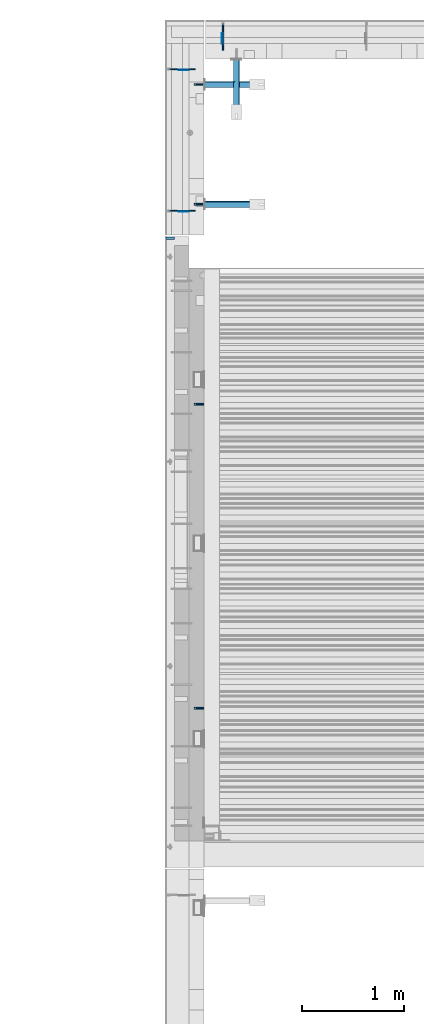
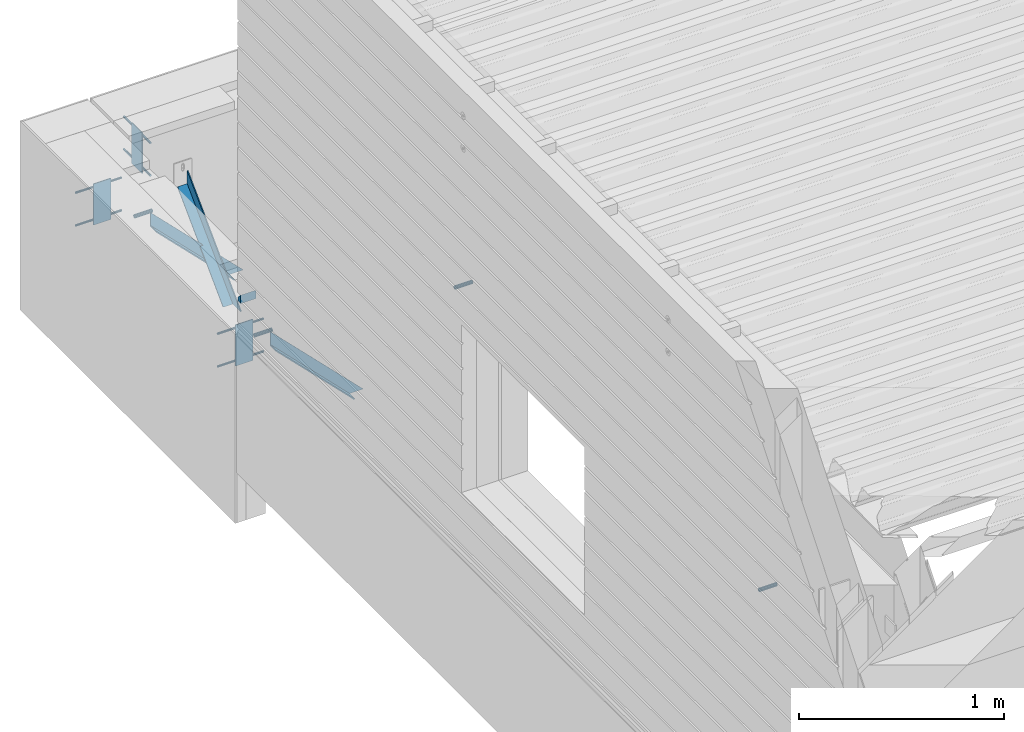
# One storey, part 51 of 153: 14 beams, 3 members, 19 elements without a shape of their own.
"""IFC2X3 building model written with IfcOpenShell, lengths in millimetres."""

from ifc_helpers import new_model, si_unit, frame, origin_with_axes, place, context, subcontext, project, spatial, faceted_brep, material, type_object, element, aggregate, save


model = new_model("IFC2X3")

# Units and contexts
model_context = context("Model", 3, precision=1e-05, world=origin_with_axes())
body_context = subcontext(model_context, "Body", "Model", "MODEL_VIEW")
ifc_project = project(units=[si_unit("LENGTHUNIT", "METRE", prefix="MILLI"), si_unit("AREAUNIT", "SQUARE_METRE"), si_unit("VOLUMEUNIT", "CUBIC_METRE"), si_unit("MASSUNIT", "GRAM", prefix="KILO"), si_unit("TIMEUNIT", "SECOND"), si_unit("PLANEANGLEUNIT", "RADIAN"), si_unit("SOLIDANGLEUNIT", "STERADIAN"), si_unit("THERMODYNAMICTEMPERATUREUNIT", "DEGREE_CELSIUS"), si_unit("LUMINOUSINTENSITYUNIT", "LUMEN")], contexts=[model_context])

# Site, building, storey
site_placement = place(None, origin_with_axes())
site = spatial("IfcSite", under=ifc_project, at=site_placement, CompositionType="ELEMENT")
building_placement = place(site_placement, origin_with_axes())
building = spatial("IfcBuilding", under=site, at=building_placement, CompositionType="ELEMENT")
storey_placement = place(building_placement, origin_with_axes())
storey = spatial("IfcBuildingStorey", under=building, at=storey_placement, Name="8", CompositionType="ELEMENT", Elevation=0.0)

# Assemblies, beams
assembly_1_placement = place(storey_placement, origin_with_axes())
assembly_1 = element("IfcElementAssembly", 1, at=assembly_1_placement, inside=storey, AssemblyPlace="NOTDEFINED", PredefinedType="REINFORCEMENT_UNIT")
assembly_2_placement = place(assembly_1_placement, origin_with_axes())
assembly_2 = element("IfcElementAssembly", 2, at=assembly_2_placement, Name="Steel Assembly", AssemblyPlace="NOTDEFINED", PredefinedType="RIGID_FRAME")
ifc_material_1 = material(Name="STEEL/Steel_Undefined")
beam_type_1 = type_object("IfcBeamType", PredefinedType="NOTDEFINED")
beam_1_placement = place(assembly_2_placement, frame((8000.0, 19245.0, 104755.0), z_axis=(0.0, 1.0, 0.0), x_axis=(-1.0, 3.00000001838171e-08, 0.0)))
beam_1 = element("IfcBeam", 3, at=beam_1_placement, type_object=beam_type_1, material=ifc_material_1, context=body_context, shape_type="Brep", body=[
    faceted_brep([(0.0, -8.49999999999272, -1.45519152283669e-11), (0.0, -7.36121593215648, 4.24999999998545), (100.000000000262, -7.36121593215648, 4.24999999998545), (100.000000000262, -8.49999999999272, -1.45519152283669e-11), (0.0, -4.24999999998545, 7.36121593216376), (100.000000000262, -4.24999999998545, 7.36121593216376), (0.0, 1.45519152283669e-11, 8.49999999998545), (100.000000000262, 1.45519152283669e-11, 8.49999999998545), (0.0, 4.25000000001455, 7.36121593216376), (100.000000000262, 4.25000000001455, 7.36121593216376), (0.0, 7.36121593217104, 4.24999999998545), (100.000000000262, 7.36121593217104, 4.24999999998545), (0.0, 8.50000000000728, 0.0), (100.000000000262, 8.50000000000728, 0.0), (0.0, 7.36121593217104, -4.25000000001455), (100.000000000262, 7.36121593217104, -4.25000000001455), (0.0, 4.25000000000728, -7.36121593219286), (100.000000000262, 4.25000000000728, -7.36121593219286), (0.0, 7.27595761418343e-12, -8.5), (100.000000000262, 7.27595761418343e-12, -8.5), (0.0, -4.24999999999272, -7.36121593217831), (100.000000000262, -4.24999999999272, -7.36121593217831), (0.0, -7.36121593215648, -4.25), (100.000000000262, -7.36121593215648, -4.25), (0.0, -10.4999999999927, -1.45519152283669e-11), (0.0, -9.09326673972828, -5.25000000001455), (100.000000000262, -9.09326673972828, -5.25000000001455), (100.000000000262, -10.4999999999927, -1.45519152283669e-11), (0.0, -5.24999999998545, -9.09326673974283), (100.000000000262, -5.24999999998545, -9.09326673974283), (0.0, 7.27595761418343e-12, -10.5), (100.000000000262, 7.27595761418343e-12, -10.5), (0.0, 5.25000000001455, -9.09326673975738), (100.000000000262, 5.25000000001455, -9.09326673975738), (0.0, 9.09326673975011, -5.25000000001455), (100.000000000262, 9.09326673975011, -5.25000000001455), (0.0, 10.5000000000073, -1.45519152283669e-11), (100.000000000262, 10.5000000000073, -1.45519152283669e-11), (0.0, 9.09326673975011, 5.25), (100.000000000262, 9.09326673975011, 5.25), (0.0, 5.25000000000728, 9.09326673972828), (100.000000000262, 5.25000000000728, 9.09326673972828), (0.0, 1.45519152283669e-11, 10.4999999999854), (100.000000000262, 1.45519152283669e-11, 10.4999999999854), (0.0, -5.24999999999272, 9.09326673972828), (100.000000000262, -5.24999999999272, 9.09326673972828), (0.0, -9.09326673972828, 5.24999999998545), (100.000000000262, -9.09326673972828, 5.24999999998545)], [[[0, 1, 2, 3]], [[1, 4, 5, 2]], [[4, 6, 7, 5]], [[6, 8, 9, 7]], [[8, 10, 11, 9]], [[10, 12, 13, 11]], [[12, 14, 15, 13]], [[14, 16, 17, 15]], [[16, 18, 19, 17]], [[18, 20, 21, 19]], [[20, 22, 23, 21]], [[22, 0, 3, 23]], [[24, 25, 26, 27]], [[25, 28, 29, 26]], [[28, 30, 31, 29]], [[30, 32, 33, 31]], [[32, 34, 35, 33]], [[34, 36, 37, 35]], [[36, 38, 39, 37]], [[38, 40, 41, 39]], [[40, 42, 43, 41]], [[42, 44, 45, 43]], [[44, 46, 47, 45]], [[46, 24, 27, 47]], [[29, 31, 33, 35, 37, 39, 41, 43, 45, 47, 27, 26], [5, 7, 9, 11, 13, 15, 17, 19, 21, 23, 3, 2]], [[46, 44, 42, 40, 38, 36, 34, 32, 30, 28, 25, 24], [22, 20, 18, 16, 14, 12, 10, 8, 6, 4, 1, 0]]]),
])
aggregate(assembly_2, [beam_1])
assembly_3_placement = place(assembly_1_placement, origin_with_axes())
assembly_3 = element("IfcElementAssembly", 4, at=assembly_3_placement, Name="Steel Assembly", AssemblyPlace="NOTDEFINED", PredefinedType="RIGID_FRAME")
beam_2_placement = place(assembly_3_placement, frame((8000.0, 16275.0, 104755.0), z_axis=(0.0, 1.0, 0.0), x_axis=(-1.0, 3.00000001838171e-08, 0.0)))
beam_2 = element("IfcBeam", 5, at=beam_2_placement, type_object=beam_type_1, material=ifc_material_1, context=body_context, shape_type="Brep", body=[
    faceted_brep([(0.0, -8.49999999999272, -1.45519152283669e-11), (0.0, -7.36121593215648, 4.24999999998545), (100.000000000262, -7.36121593215648, 4.24999999998545), (100.000000000262, -8.49999999999272, -1.45519152283669e-11), (0.0, -4.24999999998545, 7.36121593216376), (100.000000000262, -4.24999999998545, 7.36121593216376), (0.0, 1.45519152283669e-11, 8.49999999998545), (100.000000000262, 1.45519152283669e-11, 8.49999999998545), (0.0, 4.25000000001455, 7.36121593216376), (100.000000000262, 4.25000000001455, 7.36121593216376), (0.0, 7.36121593217104, 4.24999999998545), (100.000000000262, 7.36121593217104, 4.24999999998545), (0.0, 8.50000000000728, 0.0), (100.000000000262, 8.50000000000728, 0.0), (0.0, 7.36121593217104, -4.25000000001455), (100.000000000262, 7.36121593217104, -4.25000000001455), (0.0, 4.25000000000728, -7.36121593219286), (100.000000000262, 4.25000000000728, -7.36121593219286), (0.0, 7.27595761418343e-12, -8.5), (100.000000000262, 7.27595761418343e-12, -8.5), (0.0, -4.24999999999272, -7.36121593217831), (100.000000000262, -4.24999999999272, -7.36121593217831), (0.0, -7.36121593215648, -4.25), (100.000000000262, -7.36121593215648, -4.25), (0.0, -10.4999999999927, -1.45519152283669e-11), (0.0, -9.09326673972828, -5.25000000001455), (100.000000000262, -9.09326673972828, -5.25000000001455), (100.000000000262, -10.4999999999927, -1.45519152283669e-11), (0.0, -5.24999999998545, -9.09326673974283), (100.000000000262, -5.24999999998545, -9.09326673974283), (0.0, 7.27595761418343e-12, -10.5), (100.000000000262, 7.27595761418343e-12, -10.5), (0.0, 5.25000000001455, -9.09326673975738), (100.000000000262, 5.25000000001455, -9.09326673975738), (0.0, 9.09326673975011, -5.25000000001455), (100.000000000262, 9.09326673975011, -5.25000000001455), (0.0, 10.5000000000073, -1.45519152283669e-11), (100.000000000262, 10.5000000000073, -1.45519152283669e-11), (0.0, 9.09326673975011, 5.25), (100.000000000262, 9.09326673975011, 5.25), (0.0, 5.25000000000728, 9.09326673972828), (100.000000000262, 5.25000000000728, 9.09326673972828), (0.0, 1.45519152283669e-11, 10.4999999999854), (100.000000000262, 1.45519152283669e-11, 10.4999999999854), (0.0, -5.24999999999272, 9.09326673972828), (100.000000000262, -5.24999999999272, 9.09326673972828), (0.0, -9.09326673972828, 5.24999999998545), (100.000000000262, -9.09326673972828, 5.24999999998545)], [[[0, 1, 2, 3]], [[1, 4, 5, 2]], [[4, 6, 7, 5]], [[6, 8, 9, 7]], [[8, 10, 11, 9]], [[10, 12, 13, 11]], [[12, 14, 15, 13]], [[14, 16, 17, 15]], [[16, 18, 19, 17]], [[18, 20, 21, 19]], [[20, 22, 23, 21]], [[22, 0, 3, 23]], [[24, 25, 26, 27]], [[25, 28, 29, 26]], [[28, 30, 31, 29]], [[30, 32, 33, 31]], [[32, 34, 35, 33]], [[34, 36, 37, 35]], [[36, 38, 39, 37]], [[38, 40, 41, 39]], [[40, 42, 43, 41]], [[42, 44, 45, 43]], [[44, 46, 47, 45]], [[46, 24, 27, 47]], [[29, 31, 33, 35, 37, 39, 41, 43, 45, 47, 27, 26], [5, 7, 9, 11, 13, 15, 17, 19, 21, 23, 3, 2]], [[46, 44, 42, 40, 38, 36, 34, 32, 30, 28, 25, 24], [22, 20, 18, 16, 14, 12, 10, 8, 6, 4, 1, 0]]]),
])
aggregate(assembly_3, [beam_2])

assembly_4_placement = place(storey_placement, origin_with_axes())
assembly_4 = element("IfcElementAssembly", 6, at=assembly_4_placement, inside=storey, AssemblyPlace="NOTDEFINED", PredefinedType="REINFORCEMENT_UNIT")
assembly_5_placement = place(assembly_4_placement, origin_with_axes())
assembly_5 = element("IfcElementAssembly", 7, at=assembly_5_placement, Name="Steel Assembly", AssemblyPlace="NOTDEFINED", PredefinedType="RIGID_FRAME")
beam_3_placement = place(assembly_5_placement, frame((8000.00000000034, 22370.0020003493, 103285.0), z_axis=(0.0, -1.0, 0.0), x_axis=(-1.0, 3.00000001838171e-08, 0.0)))
beam_3 = element("IfcBeam", 8, at=beam_3_placement, type_object=beam_type_1, material=ifc_material_1, Name="1036-G", context=body_context, shape_type="Brep", body=[
    faceted_brep([(0.0, -8.49999999999272, -1.45519152283669e-11), (0.0, -7.36121593215648, 4.24999999998545), (100.000000000262, -7.36121593215648, 4.24999999998545), (100.000000000262, -8.49999999999272, -1.45519152283669e-11), (0.0, -4.24999999998545, 7.36121593216376), (100.000000000262, -4.24999999998545, 7.36121593216376), (0.0, 1.45519152283669e-11, 8.49999999998545), (100.000000000262, 1.45519152283669e-11, 8.49999999998545), (0.0, 4.25000000001455, 7.36121593216376), (100.000000000262, 4.25000000001455, 7.36121593216376), (0.0, 7.36121593217104, 4.24999999998545), (100.000000000262, 7.36121593217104, 4.24999999998545), (0.0, 8.50000000000728, 0.0), (100.000000000262, 8.50000000000728, 0.0), (0.0, 7.36121593217104, -4.25000000001455), (100.000000000262, 7.36121593217104, -4.25000000001455), (0.0, 4.25000000000728, -7.36121593219286), (100.000000000262, 4.25000000000728, -7.36121593219286), (0.0, 7.27595761418343e-12, -8.5), (100.000000000262, 7.27595761418343e-12, -8.5), (0.0, -4.24999999999272, -7.36121593217831), (100.000000000262, -4.24999999999272, -7.36121593217831), (0.0, -7.36121593215648, -4.25), (100.000000000262, -7.36121593215648, -4.25), (0.0, -10.4999999999927, -1.45519152283669e-11), (0.0, -9.09326673972828, -5.25000000001455), (100.000000000262, -9.09326673972828, -5.25000000001455), (100.000000000262, -10.4999999999927, -1.45519152283669e-11), (0.0, -5.24999999998545, -9.09326673974283), (100.000000000262, -5.24999999998545, -9.09326673974283), (0.0, 7.27595761418343e-12, -10.5), (100.000000000262, 7.27595761418343e-12, -10.5), (0.0, 5.25000000001455, -9.09326673975738), (100.000000000262, 5.25000000001455, -9.09326673975738), (0.0, 9.09326673975011, -5.25000000001455), (100.000000000262, 9.09326673975011, -5.25000000001455), (0.0, 10.5000000000073, -1.45519152283669e-11), (100.000000000262, 10.5000000000073, -1.45519152283669e-11), (0.0, 9.09326673975011, 5.25), (100.000000000262, 9.09326673975011, 5.25), (0.0, 5.25000000000728, 9.09326673972828), (100.000000000262, 5.25000000000728, 9.09326673972828), (0.0, 1.45519152283669e-11, 10.4999999999854), (100.000000000262, 1.45519152283669e-11, 10.4999999999854), (0.0, -5.24999999999272, 9.09326673972828), (100.000000000262, -5.24999999999272, 9.09326673972828), (0.0, -9.09326673972828, 5.24999999998545), (100.000000000262, -9.09326673972828, 5.24999999998545)], [[[0, 1, 2, 3]], [[1, 4, 5, 2]], [[4, 6, 7, 5]], [[6, 8, 9, 7]], [[8, 10, 11, 9]], [[10, 12, 13, 11]], [[12, 14, 15, 13]], [[14, 16, 17, 15]], [[16, 18, 19, 17]], [[18, 20, 21, 19]], [[20, 22, 23, 21]], [[22, 0, 3, 23]], [[24, 25, 26, 27]], [[25, 28, 29, 26]], [[28, 30, 31, 29]], [[30, 32, 33, 31]], [[32, 34, 35, 33]], [[34, 36, 37, 35]], [[36, 38, 39, 37]], [[38, 40, 41, 39]], [[40, 42, 43, 41]], [[42, 44, 45, 43]], [[44, 46, 47, 45]], [[46, 24, 27, 47]], [[29, 31, 33, 35, 37, 39, 41, 43, 45, 47, 27, 26], [5, 7, 9, 11, 13, 15, 17, 19, 21, 23, 3, 2]], [[46, 44, 42, 40, 38, 36, 34, 32, 30, 28, 25, 24], [22, 20, 18, 16, 14, 12, 10, 8, 6, 4, 1, 0]]]),
])
aggregate(assembly_5, [beam_3])
assembly_6_placement = place(assembly_4_placement, origin_with_axes())
assembly_6 = element("IfcElementAssembly", 9, at=assembly_6_placement, Name="Steel Assembly", AssemblyPlace="NOTDEFINED", PredefinedType="RIGID_FRAME")
beam_4_placement = place(assembly_6_placement, frame((8000.00000000034, 21199.9999481269, 103285.0), z_axis=(0.0, -1.0, 0.0), x_axis=(-1.0, 3.00000001838171e-08, 0.0)))
beam_4 = element("IfcBeam", 10, at=beam_4_placement, type_object=beam_type_1, material=ifc_material_1, Name="1036-G", context=body_context, shape_type="Brep", body=[
    faceted_brep([(0.0, -8.49999999999272, -1.45519152283669e-11), (0.0, -7.36121593215648, 4.24999999998545), (100.000000000262, -7.36121593215648, 4.24999999998545), (100.000000000262, -8.49999999999272, -1.45519152283669e-11), (0.0, -4.24999999998545, 7.36121593216376), (100.000000000262, -4.24999999998545, 7.36121593216376), (0.0, 1.45519152283669e-11, 8.49999999998545), (100.000000000262, 1.45519152283669e-11, 8.49999999998545), (0.0, 4.25000000001455, 7.36121593216376), (100.000000000262, 4.25000000001455, 7.36121593216376), (0.0, 7.36121593217104, 4.24999999998545), (100.000000000262, 7.36121593217104, 4.24999999998545), (0.0, 8.50000000000728, 0.0), (100.000000000262, 8.50000000000728, 0.0), (0.0, 7.36121593217104, -4.25000000001455), (100.000000000262, 7.36121593217104, -4.25000000001455), (0.0, 4.25000000000728, -7.36121593219286), (100.000000000262, 4.25000000000728, -7.36121593219286), (0.0, 7.27595761418343e-12, -8.5), (100.000000000262, 7.27595761418343e-12, -8.5), (0.0, -4.24999999999272, -7.36121593217831), (100.000000000262, -4.24999999999272, -7.36121593217831), (0.0, -7.36121593215648, -4.25), (100.000000000262, -7.36121593215648, -4.25), (0.0, -10.4999999999927, -1.45519152283669e-11), (0.0, -9.09326673972828, -5.25000000001455), (100.000000000262, -9.09326673972828, -5.25000000001455), (100.000000000262, -10.4999999999927, -1.45519152283669e-11), (0.0, -5.24999999998545, -9.09326673974283), (100.000000000262, -5.24999999998545, -9.09326673974283), (0.0, 7.27595761418343e-12, -10.5), (100.000000000262, 7.27595761418343e-12, -10.5), (0.0, 5.25000000001455, -9.09326673975738), (100.000000000262, 5.25000000001455, -9.09326673975738), (0.0, 9.09326673975011, -5.25000000001455), (100.000000000262, 9.09326673975011, -5.25000000001455), (0.0, 10.5000000000073, -1.45519152283669e-11), (100.000000000262, 10.5000000000073, -1.45519152283669e-11), (0.0, 9.09326673975011, 5.25), (100.000000000262, 9.09326673975011, 5.25), (0.0, 5.25000000000728, 9.09326673972828), (100.000000000262, 5.25000000000728, 9.09326673972828), (0.0, 1.45519152283669e-11, 10.4999999999854), (100.000000000262, 1.45519152283669e-11, 10.4999999999854), (0.0, -5.24999999999272, 9.09326673972828), (100.000000000262, -5.24999999999272, 9.09326673972828), (0.0, -9.09326673972828, 5.24999999998545), (100.000000000262, -9.09326673972828, 5.24999999998545)], [[[0, 1, 2, 3]], [[1, 4, 5, 2]], [[4, 6, 7, 5]], [[6, 8, 9, 7]], [[8, 10, 11, 9]], [[10, 12, 13, 11]], [[12, 14, 15, 13]], [[14, 16, 17, 15]], [[16, 18, 19, 17]], [[18, 20, 21, 19]], [[20, 22, 23, 21]], [[22, 0, 3, 23]], [[24, 25, 26, 27]], [[25, 28, 29, 26]], [[28, 30, 31, 29]], [[30, 32, 33, 31]], [[32, 34, 35, 33]], [[34, 36, 37, 35]], [[36, 38, 39, 37]], [[38, 40, 41, 39]], [[40, 42, 43, 41]], [[42, 44, 45, 43]], [[44, 46, 47, 45]], [[46, 24, 27, 47]], [[29, 31, 33, 35, 37, 39, 41, 43, 45, 47, 27, 26], [5, 7, 9, 11, 13, 15, 17, 19, 21, 23, 3, 2]], [[46, 44, 42, 40, 38, 36, 34, 32, 30, 28, 25, 24], [22, 20, 18, 16, 14, 12, 10, 8, 6, 4, 1, 0]]]),
])
aggregate(assembly_6, [beam_4])

# Beam
ifc_material_2 = material(Name="TIMBER/T24")
beam_type_2 = type_object("IfcBeamType", PredefinedType="NOTDEFINED")
beam_5_placement = place(assembly_1_placement, frame((7625.0, 20867.5, 103805.0), z_axis=(0.0, 1.0, 0.0), x_axis=(1.0, 0.0, 0.0)))
beam_5 = element("IfcBeam", 11, at=beam_5_placement, type_object=beam_type_2, material=ifc_material_2, context=body_context, shape_type="Brep", body=[
    faceted_brep([(85.0, -6.35918695479631e-09, 12.4999999935644), (1.45519152283669e-11, -3.63797880709171e-12, 12.4999999999964), (0.0, -25.0, -12.5), (85.0, -25.0, -12.5), (0.0, 25.0, -12.5), (0.0, 25.0, 12.5), (85.0, 25.0, 12.5), (85.0, 25.0, -12.5)], [[[0, 1, 2, 3]], [[4, 5, 6, 7]], [[7, 6, 0, 3]], [[4, 7, 3, 2]], [[5, 4, 2, 1]], [[6, 5, 1, 0]]]),
])

aggregate(assembly_1, [assembly_2, beam_5, assembly_3])

# Assemblies, beams
assembly_7_placement = place(storey_placement, origin_with_axes())
assembly_7 = element("IfcElementAssembly", 12, at=assembly_7_placement, inside=storey, AssemblyPlace="NOTDEFINED", PredefinedType="REINFORCEMENT_UNIT")
assembly_8_placement = place(assembly_7_placement, origin_with_axes())
assembly_8 = element("IfcElementAssembly", 13, at=assembly_8_placement, Name="Steel Assembly", AssemblyPlace="NOTDEFINED", PredefinedType="RIGID_FRAME")
beam_type_3 = type_object("IfcBeamType", Name="D12", PredefinedType="NOTDEFINED")
beam_6_placement = place(assembly_8_placement, frame((8184.99341918893, 22704.9948219476, 103224.99266456), z_axis=(-1.0, 3.00000001838171e-08, 0.0), x_axis=(-1.71000001528888e-07, 0.999999999916793, 1.28990000076059e-05)))
beam_6 = element("IfcBeam", 14, at=beam_6_placement, type_object=beam_type_3, material=ifc_material_1, Name="M12", ObjectType="D12", context=body_context, shape_type="Brep", body=[
    faceted_brep([(0.0, -6.0, -1.45519152283669e-11), (0.0, -4.24264068712, -4.24264068713819), (260.003353918641, -4.24264068710909, -4.24264068711909), (260.003353918641, -6.0, 0.0), (3.63797880709171e-12, 0.0, -6.0000000000291), (260.003353918644, 0.0, -6.0), (0.0, 4.24264068712, -4.24264068713819), (260.003353918641, 4.24264068710909, -4.24264068711909), (0.0, 6.0, -1.45519152283669e-11), (260.003353918644, 6.0, 9.09494701772928e-13), (0.0, 4.24264068712, 4.24264068709454), (260.003353918641, 4.24264068710909, 4.24264068711909), (0.0, 0.0, 5.99999999998545), (260.003353918644, 0.0, 6.0), (0.0, -4.24264068712, 4.24264068709454), (260.003353918641, -4.24264068710909, 4.24264068711909)], [[[0, 1, 2, 3]], [[1, 4, 5, 2]], [[4, 6, 7, 5]], [[6, 8, 9, 7]], [[8, 10, 11, 9]], [[10, 12, 13, 11]], [[12, 14, 15, 13]], [[14, 0, 3, 15]], [[5, 7, 9, 11, 13, 15, 3, 2]], [[14, 12, 10, 8, 6, 4, 1, 0]]]),
])
aggregate(assembly_8, [beam_6])
assembly_9_placement = place(assembly_7_placement, origin_with_axes())
assembly_9 = element("IfcElementAssembly", 15, at=assembly_9_placement, Name="Steel Assembly", AssemblyPlace="NOTDEFINED", PredefinedType="RIGID_FRAME")
beam_7_placement = place(assembly_9_placement, frame((8184.99341918893, 22704.9948219476, 103419.99266456), z_axis=(-1.0, 3.00000001838171e-08, 0.0), x_axis=(-1.71000001528888e-07, 0.999999999916793, 1.28990000076059e-05)))
beam_7 = element("IfcBeam", 16, at=beam_7_placement, type_object=beam_type_3, material=ifc_material_1, Name="M12", ObjectType="D12", context=body_context, shape_type="Brep", body=[
    faceted_brep([(0.0, -6.0, -1.45519152283669e-11), (0.0, -4.24264068712, -4.24264068713819), (260.003353918641, -4.24264068710909, -4.24264068711909), (260.003353918641, -6.0, 0.0), (3.63797880709171e-12, 0.0, -6.0000000000291), (260.003353918644, 0.0, -6.0), (0.0, 4.24264068712, -4.24264068713819), (260.003353918641, 4.24264068710909, -4.24264068711909), (0.0, 6.0, -1.45519152283669e-11), (260.003353918644, 6.0, 9.09494701772928e-13), (0.0, 4.24264068712, 4.24264068709454), (260.003353918641, 4.24264068710909, 4.24264068711909), (0.0, 0.0, 5.99999999998545), (260.003353918644, 0.0, 6.0), (0.0, -4.24264068712, 4.24264068709454), (260.003353918641, -4.24264068710909, 4.24264068711909)], [[[0, 1, 2, 3]], [[1, 4, 5, 2]], [[4, 6, 7, 5]], [[6, 8, 9, 7]], [[8, 10, 11, 9]], [[10, 12, 13, 11]], [[12, 14, 15, 13]], [[14, 0, 3, 15]], [[5, 7, 9, 11, 13, 15, 3, 2]], [[14, 12, 10, 8, 6, 4, 1, 0]]]),
])
aggregate(assembly_9, [beam_7])

# Assembly, beam
assembly_10_placement = place(assembly_4_placement, origin_with_axes())
assembly_10 = element("IfcElementAssembly", 17, at=assembly_10_placement, Name="Steel Assembly", AssemblyPlace="NOTDEFINED", PredefinedType="RIGID_FRAME")
beam_8_placement = place(assembly_10_placement, frame((7915.00517805244, 21135.0034191889, 103224.99266456), z_axis=(0.0, -1.0, 0.0), x_axis=(-0.999999999916793, -1.71000001528888e-07, 1.28990000076059e-05)))
beam_8 = element("IfcBeam", 18, at=beam_8_placement, type_object=beam_type_3, material=ifc_material_1, Name="M12", ObjectType="D12", context=body_context, shape_type="Brep", body=[
    faceted_brep([(0.0, -6.0, -1.45519152283669e-11), (0.0, -4.24264068712, -4.24264068713819), (260.003353918641, -4.24264068710909, -4.24264068711909), (260.003353918641, -6.0, 0.0), (3.63797880709171e-12, 0.0, -6.0000000000291), (260.003353918644, 0.0, -6.0), (0.0, 4.24264068712, -4.24264068713819), (260.003353918641, 4.24264068710909, -4.24264068711909), (0.0, 6.0, -1.45519152283669e-11), (260.003353918644, 6.0, 9.09494701772928e-13), (0.0, 4.24264068712, 4.24264068709454), (260.003353918641, 4.24264068710909, 4.24264068711909), (0.0, 0.0, 5.99999999998545), (260.003353918644, 0.0, 6.0), (0.0, -4.24264068712, 4.24264068709454), (260.003353918641, -4.24264068710909, 4.24264068711909)], [[[0, 1, 2, 3]], [[1, 4, 5, 2]], [[4, 6, 7, 5]], [[6, 8, 9, 7]], [[8, 10, 11, 9]], [[10, 12, 13, 11]], [[12, 14, 15, 13]], [[14, 0, 3, 15]], [[5, 7, 9, 11, 13, 15, 3, 2]], [[14, 12, 10, 8, 6, 4, 1, 0]]]),
])
aggregate(assembly_10, [beam_8])

assembly_11_placement = place(assembly_4_placement, origin_with_axes())
assembly_11 = element("IfcElementAssembly", 19, at=assembly_11_placement, Name="Steel Assembly", AssemblyPlace="NOTDEFINED", PredefinedType="RIGID_FRAME")
beam_9_placement = place(assembly_11_placement, frame((7915.00517805244, 21135.0034191889, 103419.99266456), z_axis=(0.0, -1.0, 0.0), x_axis=(-0.999999999916793, -1.71000001528888e-07, 1.28990000076059e-05)))
beam_9 = element("IfcBeam", 20, at=beam_9_placement, type_object=beam_type_3, material=ifc_material_1, Name="M12", ObjectType="D12", context=body_context, shape_type="Brep", body=[
    faceted_brep([(0.0, -6.0, -1.45519152283669e-11), (0.0, -4.24264068712, -4.24264068713819), (260.003353918641, -4.24264068710909, -4.24264068711909), (260.003353918641, -6.0, 0.0), (3.63797880709171e-12, 0.0, -6.0000000000291), (260.003353918644, 0.0, -6.0), (0.0, 4.24264068712, -4.24264068713819), (260.003353918641, 4.24264068710909, -4.24264068711909), (0.0, 6.0, -1.45519152283669e-11), (260.003353918644, 6.0, 9.09494701772928e-13), (0.0, 4.24264068712, 4.24264068709454), (260.003353918641, 4.24264068710909, 4.24264068711909), (0.0, 0.0, 5.99999999998545), (260.003353918644, 0.0, 6.0), (0.0, -4.24264068712, 4.24264068709454), (260.003353918641, -4.24264068710909, 4.24264068711909)], [[[0, 1, 2, 3]], [[1, 4, 5, 2]], [[4, 6, 7, 5]], [[6, 8, 9, 7]], [[8, 10, 11, 9]], [[10, 12, 13, 11]], [[12, 14, 15, 13]], [[14, 0, 3, 15]], [[5, 7, 9, 11, 13, 15, 3, 2]], [[14, 12, 10, 8, 6, 4, 1, 0]]]),
])
aggregate(assembly_11, [beam_9])

assembly_12_placement = place(assembly_4_placement, origin_with_axes())
assembly_12 = element("IfcElementAssembly", 21, at=assembly_12_placement, Name="Steel Assembly", AssemblyPlace="NOTDEFINED", PredefinedType="RIGID_FRAME")
beam_10_placement = place(assembly_12_placement, frame((7915.00517805244, 22520.0034191889, 103224.99266456), z_axis=(0.0, -1.0, 0.0), x_axis=(-0.999999999916793, -1.71000001528888e-07, 1.28990000076059e-05)))
beam_10 = element("IfcBeam", 22, at=beam_10_placement, type_object=beam_type_3, material=ifc_material_1, Name="M12", ObjectType="D12", context=body_context, shape_type="Brep", body=[
    faceted_brep([(0.0, -6.0, -1.45519152283669e-11), (0.0, -4.24264068712, -4.24264068713819), (260.003353918641, -4.24264068710909, -4.24264068711909), (260.003353918641, -6.0, 0.0), (3.63797880709171e-12, 0.0, -6.0000000000291), (260.003353918644, 0.0, -6.0), (0.0, 4.24264068712, -4.24264068713819), (260.003353918641, 4.24264068710909, -4.24264068711909), (0.0, 6.0, -1.45519152283669e-11), (260.003353918644, 6.0, 9.09494701772928e-13), (0.0, 4.24264068712, 4.24264068709454), (260.003353918641, 4.24264068710909, 4.24264068711909), (0.0, 0.0, 5.99999999998545), (260.003353918644, 0.0, 6.0), (0.0, -4.24264068712, 4.24264068709454), (260.003353918641, -4.24264068710909, 4.24264068711909)], [[[0, 1, 2, 3]], [[1, 4, 5, 2]], [[4, 6, 7, 5]], [[6, 8, 9, 7]], [[8, 10, 11, 9]], [[10, 12, 13, 11]], [[12, 14, 15, 13]], [[14, 0, 3, 15]], [[5, 7, 9, 11, 13, 15, 3, 2]], [[14, 12, 10, 8, 6, 4, 1, 0]]]),
])
aggregate(assembly_12, [beam_10])

assembly_13_placement = place(assembly_4_placement, origin_with_axes())
assembly_13 = element("IfcElementAssembly", 23, at=assembly_13_placement, Name="Steel Assembly", AssemblyPlace="NOTDEFINED", PredefinedType="RIGID_FRAME")
beam_11_placement = place(assembly_13_placement, frame((7915.00517805244, 22520.0034191889, 103419.99266456), z_axis=(0.0, -1.0, 0.0), x_axis=(-0.999999999916793, -1.71000001528888e-07, 1.28990000076059e-05)))
beam_11 = element("IfcBeam", 24, at=beam_11_placement, type_object=beam_type_3, material=ifc_material_1, Name="M12", ObjectType="D12", context=body_context, shape_type="Brep", body=[
    faceted_brep([(0.0, -6.0, -1.45519152283669e-11), (0.0, -4.24264068712, -4.24264068713819), (260.003353918641, -4.24264068710909, -4.24264068711909), (260.003353918641, -6.0, 0.0), (3.63797880709171e-12, 0.0, -6.0000000000291), (260.003353918644, 0.0, -6.0), (0.0, 4.24264068712, -4.24264068713819), (260.003353918641, 4.24264068710909, -4.24264068711909), (0.0, 6.0, -1.45519152283669e-11), (260.003353918644, 6.0, 9.09494701772928e-13), (0.0, 4.24264068712, 4.24264068709454), (260.003353918641, 4.24264068710909, 4.24264068711909), (0.0, 0.0, 5.99999999998545), (260.003353918644, 0.0, 6.0), (0.0, -4.24264068712, 4.24264068709454), (260.003353918641, -4.24264068710909, 4.24264068711909)], [[[0, 1, 2, 3]], [[1, 4, 5, 2]], [[4, 6, 7, 5]], [[6, 8, 9, 7]], [[8, 10, 11, 9]], [[10, 12, 13, 11]], [[12, 14, 15, 13]], [[14, 0, 3, 15]], [[5, 7, 9, 11, 13, 15, 3, 2]], [[14, 12, 10, 8, 6, 4, 1, 0]]]),
])
aggregate(assembly_13, [beam_11])

# Assembly
assembly_14_placement = place(assembly_7_placement, origin_with_axes())
assembly_14 = element("IfcElementAssembly", 25, at=assembly_14_placement, Name="Steel Assembly", AssemblyPlace="NOTDEFINED", PredefinedType="RIGID_FRAME")

aggregate(assembly_7, [assembly_8, assembly_14, assembly_9])

# Beam
ifc_material_3 = material(Name="STEEL/1.4301")
beam_type_4 = type_object("IfcBeamType", PredefinedType="NOTDEFINED")
beam_12_placement = place(assembly_14_placement, frame((8176.49477281603, 22819.9981743288, 103444.99266456), z_axis=(0.0, 1.0, 0.0), x_axis=(0.0, 0.0, -1.0)))
beam_12 = element("IfcBeam", 26, at=beam_12_placement, type_object=beam_type_4, material=ifc_material_3, Name="RST", context=body_context, shape_type="Brep", body=[
    faceted_brep([(0.0, 2.5, -49.9999999999964), (0.0, 2.49999999999909, 50.0000000000036), (245.0, 2.49999999999909, 50.0000000000036), (245.0, 2.5, -49.9999999999964), (0.0, -2.50000000000091, 50.0000000000036), (245.0, -2.50000000000091, 50.0000000000036), (0.0, -2.50000000000091, -49.9999999999964), (245.0, -2.50000000000091, -49.9999999999964)], [[[0, 1, 2, 3]], [[1, 4, 5, 2]], [[4, 6, 7, 5]], [[6, 0, 3, 7]], [[5, 7, 3, 2]], [[6, 4, 1, 0]]]),
])

aggregate(assembly_14, [beam_12])

# Assembly, beam
assembly_15_placement = place(assembly_4_placement, origin_with_axes())
assembly_15 = element("IfcElementAssembly", 27, at=assembly_15_placement, Name="Steel Assembly", AssemblyPlace="NOTDEFINED", PredefinedType="RIGID_FRAME")
beam_13_placement = place(assembly_15_placement, frame((7800.00182567124, 21126.504772816, 103444.99266456), z_axis=(-1.0, 3.00000001838171e-08, 0.0), x_axis=(0.0, 0.0, -1.0)))
beam_13 = element("IfcBeam", 28, at=beam_13_placement, type_object=beam_type_4, material=ifc_material_3, Name="RST", context=body_context, shape_type="Brep", body=[
    faceted_brep([(0.0, 2.5, -49.9999999999964), (0.0, 2.49999999999909, 50.0000000000036), (245.0, 2.49999999999909, 50.0000000000036), (245.0, 2.5, -49.9999999999964), (0.0, -2.50000000000091, 50.0000000000036), (245.0, -2.50000000000091, 50.0000000000036), (0.0, -2.50000000000091, -49.9999999999964), (245.0, -2.50000000000091, -49.9999999999964)], [[[0, 1, 2, 3]], [[1, 4, 5, 2]], [[4, 6, 7, 5]], [[6, 0, 3, 7]], [[5, 7, 3, 2]], [[6, 4, 1, 0]]]),
])
aggregate(assembly_15, [beam_13])

# Assembly
assembly_16_placement = place(assembly_4_placement, origin_with_axes())
assembly_16 = element("IfcElementAssembly", 29, at=assembly_16_placement, Name="Steel Assembly", AssemblyPlace="NOTDEFINED", PredefinedType="RIGID_FRAME")

aggregate(assembly_4, [assembly_5, assembly_6, assembly_10, assembly_15, assembly_11, assembly_12, assembly_16, assembly_13])

# Beam
beam_14_placement = place(assembly_16_placement, frame((7800.00182567124, 22511.504772816, 103444.99266456), z_axis=(-1.0, 3.00000001838171e-08, 0.0), x_axis=(0.0, 0.0, -1.0)))
beam_14 = element("IfcBeam", 30, at=beam_14_placement, type_object=beam_type_4, material=ifc_material_3, Name="RST", context=body_context, shape_type="Brep", body=[
    faceted_brep([(0.0, 2.5, -49.9999999999964), (0.0, 2.49999999999909, 50.0000000000036), (245.0, 2.49999999999909, 50.0000000000036), (245.0, 2.5, -49.9999999999964), (0.0, -2.50000000000091, 50.0000000000036), (245.0, -2.50000000000091, 50.0000000000036), (0.0, -2.50000000000091, -49.9999999999964), (245.0, -2.50000000000091, -49.9999999999964)], [[[0, 1, 2, 3]], [[1, 4, 5, 2]], [[4, 6, 7, 5]], [[6, 0, 3, 7]], [[5, 7, 3, 2]], [[6, 4, 1, 0]]]),
])

aggregate(assembly_16, [beam_14])

# Assembly, member
assembly_17_placement = place(storey_placement, origin_with_axes())
assembly_17 = element("IfcElementAssembly", 31, at=assembly_17_placement, inside=storey, Name="Steel Assembly", AssemblyPlace="NOTDEFINED", PredefinedType="RIGID_FRAME")
ifc_material_4 = material(Name="STEEL/S355J2")
member_type = type_object("IfcMemberType", PredefinedType="NOTDEFINED")
member_1_placement = place(assembly_17_placement, frame((7984.7567567571, 22370.0020003504, 103233.816878982), z_axis=(0.708108108195998, 0.0, 0.706104034195447), x_axis=(0.706104034195441, 0.0, -0.708108108196004)))
member_1 = element("IfcMember", 32, at=member_1_placement, type_object=member_type, material=ifc_material_4, Name="2", context=body_context, shape_type="Brep", body=[
    faceted_brep([(60.1702928045706, 30.0, -30.0), (-5.28234522789717e-09, 30.0, 30.0), (739.999999918371, 30.0, 30.0000000000146), (680.169810768777, 30.0, -30.0), (-5.28234522789717e-09, 24.0, 30.0), (739.999999918371, 24.0, 30.0000000000146), (54.1532635235926, 24.0, -24.0), (686.152829683742, 24.0, -23.9999999999854), (54.1532635235926, -30.0, -24.0), (686.152829683742, -30.0, -23.9999999999854), (60.1702928045706, -30.0, -30.0), (680.169810768777, -30.0, -30.0)], [[[0, 1, 2, 3]], [[1, 4, 5, 2]], [[4, 6, 7, 5]], [[6, 8, 9, 7]], [[8, 10, 11, 9]], [[10, 0, 3, 11]], [[5, 7, 9, 11, 3, 2]], [[10, 8, 6, 4, 1, 0]]]),
])
aggregate(assembly_17, [member_1])

assembly_18_placement = place(storey_placement, origin_with_axes())
assembly_18 = element("IfcElementAssembly", 33, at=assembly_18_placement, inside=storey, Name="Steel Assembly", AssemblyPlace="NOTDEFINED", PredefinedType="RIGID_FRAME")
member_2_placement = place(assembly_18_placement, frame((8315.0, 22635.2432432444, 103233.816878982), z_axis=(0.0, -0.708108108195998, 0.706104034195447), x_axis=(0.0, -0.706104034195442, -0.708108108196003)))
member_2 = element("IfcMember", 34, at=member_2_placement, type_object=member_type, material=ifc_material_4, Name="2", context=body_context, shape_type="Brep", body=[
    faceted_brep([(60.1702928045706, 30.0, -30.0), (-5.28234522789717e-09, 30.0, 30.0), (739.999999918371, 30.0, 30.0000000000146), (680.169810768777, 30.0, -30.0), (-5.28234522789717e-09, 24.0, 30.0), (739.999999918371, 24.0, 30.0000000000146), (54.1532635235926, 24.0, -24.0), (686.152829683742, 24.0, -23.9999999999854), (54.1532635235926, -30.0, -24.0), (686.152829683742, -30.0, -23.9999999999854), (60.1702928045706, -30.0, -30.0), (680.169810768777, -30.0, -30.0)], [[[0, 1, 2, 3]], [[1, 4, 5, 2]], [[4, 6, 7, 5]], [[6, 8, 9, 7]], [[8, 10, 11, 9]], [[10, 0, 3, 11]], [[5, 7, 9, 11, 3, 2]], [[10, 8, 6, 4, 1, 0]]]),
])
aggregate(assembly_18, [member_2])

assembly_19_placement = place(storey_placement, origin_with_axes())
assembly_19 = element("IfcElementAssembly", 35, at=assembly_19_placement, inside=storey, Name="Steel Assembly", AssemblyPlace="NOTDEFINED", PredefinedType="RIGID_FRAME")
member_3_placement = place(assembly_19_placement, frame((7984.7567567571, 21199.999948128, 103233.816878981), z_axis=(0.708108108195998, 0.0, 0.706104034195447), x_axis=(0.706104034195441, 0.0, -0.708108108196004)))
member_3 = element("IfcMember", 36, at=member_3_placement, type_object=member_type, material=ifc_material_4, Name="2", context=body_context, shape_type="Brep", body=[
    faceted_brep([(60.1702928045706, 30.0, -30.0), (-5.28234522789717e-09, 30.0, 30.0), (739.999999918371, 30.0, 30.0000000000146), (680.169810768777, 30.0, -30.0), (-5.28234522789717e-09, 24.0, 30.0), (739.999999918371, 24.0, 30.0000000000146), (54.1532635235926, 24.0, -24.0), (686.152829683742, 24.0, -23.9999999999854), (54.1532635235926, -30.0, -24.0), (686.152829683742, -30.0, -23.9999999999854), (60.1702928045706, -30.0, -30.0), (680.169810768777, -30.0, -30.0)], [[[0, 1, 2, 3]], [[1, 4, 5, 2]], [[4, 6, 7, 5]], [[6, 8, 9, 7]], [[8, 10, 11, 9]], [[10, 0, 3, 11]], [[5, 7, 9, 11, 3, 2]], [[10, 8, 6, 4, 1, 0]]]),
])
aggregate(assembly_19, [member_3])

save(model, "model.ifc")
